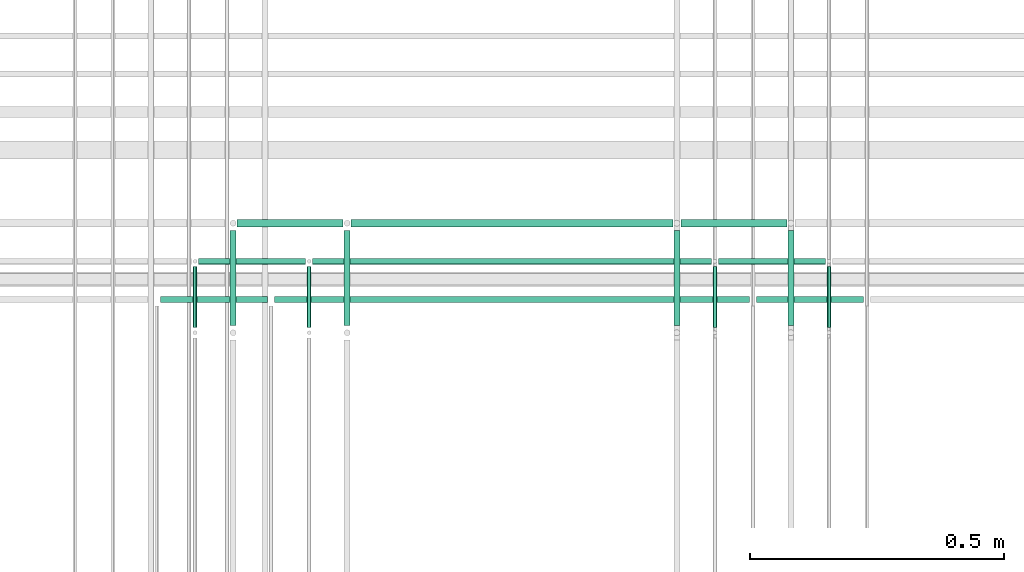
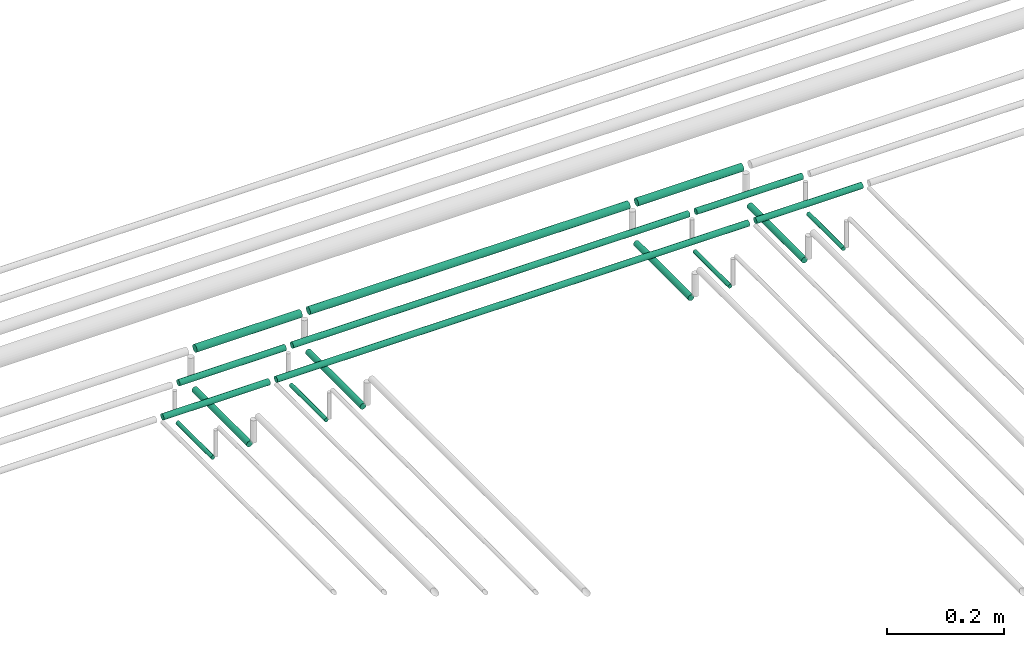
# One storey, part 141 of 331: 17 flow segments.
"""IFC2X3 building model written with IfcOpenShell, lengths in millimetres."""

import ifcopenshell
import ifcopenshell.guid

model = None  # the IFC model being written
_history = None  # IfcOwnerHistory: only IFC2X3 demands one
_inside = {}  # id of a spatial element -> (the spatial element, [elements in it])
_under = {}  # id of a project, library or spatial element -> (it, [spatial elements below it])
_declared = {}  # id of a project -> (the project, [libraries it declares])
_typed = {}  # id of a type object -> (the type object, [elements of that type])
_made_of = {}  # id of a material, layer set ... -> (it, [elements and type objects made of it])


def new_model(schema):
    """Start an empty IFC model of exactly this schema.

    Asked for "IFC4X3", IfcOpenShell would pick the latest addendum, in which some entities
    have other attributes; the version numbers below select the first issue.
    IFC2X3 requires an IfcOwnerHistory on every rooted entity: one is made here for all.
    """
    global model, _history
    if schema == "IFC4X3":
        model = ifcopenshell.file(schema_version=(4, 3, 0, 0))
    else:
        model = ifcopenshell.file(schema=schema)
    _inside.clear()
    _under.clear()
    _declared.clear()
    _typed.clear()
    _made_of.clear()
    _history = None
    if model.schema == "IFC2X3":
        org = make("IfcOrganization", Name="unknown")
        user = make(
            "IfcPersonAndOrganization",
            ThePerson=make("IfcPerson", FamilyName="unknown"),
            TheOrganization=org,
        )
        app = make(
            "IfcApplication",
            ApplicationDeveloper=org,
            Version="unknown",
            ApplicationFullName="unknown",
            ApplicationIdentifier="unknown",
        )
        _history = make(
            "IfcOwnerHistory",
            OwningUser=user,
            OwningApplication=app,
            ChangeAction="ADDED",
            CreationDate=0,
        )
    return model


def make(cls, **values):
    """One entity of the class cls with the attributes given. An attribute that is None is left unset."""
    return model.create_entity(
        cls, **{name: value for name, value in values.items() if value is not None}
    )


def entity(cls, *values):
    """Any entity or typed value of the class cls, its attributes in the order of the schema. None: left unset."""
    e = model.create_entity(cls)
    for i, value in enumerate(values):
        if value is not None:
            e[i] = value
    return e


def rooted(cls, **values):
    """An entity with a GlobalId (a new one), such as an element, a storey or a relation."""
    return make(cls, GlobalId=ifcopenshell.guid.new(), OwnerHistory=_history, **values)


def si_unit(unit_type, name, prefix=None):
    """IfcSIUnit, for example si_unit("LENGTHUNIT", "METRE", prefix="MILLI")."""
    return make("IfcSIUnit", UnitType=unit_type, Prefix=prefix, Name=name)


def converted_unit(unit_type, name, factor, base, dimensions=None, offset=None):
    """IfcConversionBasedUnit, such as the inch: factor (a typed value) times the base unit."""
    return make(
        "IfcConversionBasedUnit"
        if offset is None
        else "IfcConversionBasedUnitWithOffset",
        ConversionOffset=offset,
        Dimensions=None
        if dimensions is None
        else entity("IfcDimensionalExponents", *dimensions),
        UnitType=unit_type,
        Name=name,
        ConversionFactor=make(
            "IfcMeasureWithUnit", ValueComponent=factor, UnitComponent=base
        ),
    )


def derived_unit(unit_type, elements):
    """IfcDerivedUnit: a product of units, each with its exponent."""
    return make(
        "IfcDerivedUnit",
        Elements=[
            make("IfcDerivedUnitElement", Unit=unit, Exponent=power)
            for unit, power in elements
        ],
        UnitType=unit_type,
    )


def assignment(units):
    """IfcUnitAssignment: the units of a project."""
    return None if units is None else make("IfcUnitAssignment", Units=units)


def point(xyz):
    """IfcCartesianPoint."""
    return None if xyz is None else make("IfcCartesianPoint", Coordinates=xyz)


def direction(xyz):
    """IfcDirection."""
    return None if xyz is None else make("IfcDirection", DirectionRatios=xyz)


def frame(location, z_axis=None, x_axis=None):
    """IfcAxis2Placement3D, a coordinate frame: its origin and axes. An axis left out is left unset."""
    return make(
        "IfcAxis2Placement3D",
        Location=point(location),
        Axis=direction(z_axis),
        RefDirection=direction(x_axis),
    )


def frame_2d(location, x_axis=None):
    """IfcAxis2Placement2D, a coordinate frame in the plane: its origin and x axis."""
    return make(
        "IfcAxis2Placement2D", Location=point(location), RefDirection=direction(x_axis)
    )


def origin():
    """The frame at (0, 0, 0) with its axes left unset."""
    return frame((0.0, 0.0, 0.0))


def origin_2d_with_axis():
    """The frame at (0, 0) in the plane with the x axis (1, 0) written out."""
    return frame_2d((0.0, 0.0), x_axis=(1.0, 0.0))


def place(relative_to, where):
    """IfcLocalPlacement: puts the frame where relative to a parent placement (None: the world)."""
    return make(
        "IfcLocalPlacement", PlacementRelTo=relative_to, RelativePlacement=where
    )


def context(
    kind, dimensions, precision=None, world=None, true_north=None, identifier=None
):
    """IfcGeometricRepresentationContext, for example the 3D "Model" context."""
    return make(
        "IfcGeometricRepresentationContext",
        ContextIdentifier=identifier,
        ContextType=kind,
        CoordinateSpaceDimension=dimensions,
        Precision=precision,
        WorldCoordinateSystem=world,
        TrueNorth=true_north,
    )


def subcontext(parent, identifier, kind, view, scale=None):
    """IfcGeometricRepresentationSubContext, for example "Body" below "Model"."""
    return make(
        "IfcGeometricRepresentationSubContext",
        ContextIdentifier=identifier,
        ContextType=kind,
        ParentContext=parent,
        TargetScale=scale,
        TargetView=view,
    )


def project(units=None, contexts=None):
    """IfcProject with its units and contexts."""
    return rooted(
        "IfcProject",
        Name="project",
        RepresentationContexts=contexts,
        UnitsInContext=assignment(units),
    )


def spatial(cls, under=None, at=None, **own):
    """A site, building, storey or space (cls), placed at a placement, below another one or the project."""
    s = rooted(cls, ObjectPlacement=at, **own)
    if under is not None:
        _under.setdefault(under.id(), (under, []))[1].append(s)
    return s


def profile(cls, at=None, kind="AREA", **sizes):
    """A parametric profile (cls). Its sizes go by their IFC names, for example OverallWidth=200.0."""
    return make(cls, ProfileType=kind, Position=at, **sizes)


def circle(**sizes):
    """IfcCircleProfileDef."""
    return profile("IfcCircleProfileDef", **sizes)


def extrude(swept, where, along, depth):
    """IfcExtrudedAreaSolid: the profile swept, set in the frame where, extruded along a direction by depth."""
    return make(
        "IfcExtrudedAreaSolid",
        SweptArea=swept,
        Position=where,
        ExtrudedDirection=direction(along),
        Depth=depth,
    )


def shape(context_of_items, identifier, shape_type, items):
    """IfcShapeRepresentation: the items that make up one representation, for example the "Body"."""
    return make(
        "IfcShapeRepresentation",
        ContextOfItems=context_of_items,
        RepresentationIdentifier=identifier,
        RepresentationType=shape_type,
        Items=items,
    )


def made_of(thing, what):
    """Note that an element or type object is made of a material, layer set ...; save() writes the relation."""
    if what is not None:
        _made_of.setdefault(what.id(), (what, []))[1].append(thing)
    return thing


def type_object(cls, material=None, **own):
    """A type object (cls), such as IfcWallType, which elements share."""
    return made_of(rooted(cls, **own), material)


def element(
    cls,
    number,
    at=None,
    inside=None,
    cuts=None,
    type_object=None,
    material=None,
    context=None,
    identifier="Body",
    shape_type=None,
    held_by="IfcProductDefinitionShape",
    body=None,
    shapes=None,
    **own,
):
    """One element of the class cls, such as IfcWall. Its Tag is "e" and its number.

    at: its placement. inside: the storey or other place that contains it. cuts: it is an
    opening in that element (IfcRelVoidsElement). A single representation is given by context,
    identifier, shape_type and body (its items); several are given by shapes. held_by: the class
    of the entity that holds the representations. save() writes the other relations.
    """
    e = rooted(cls, Tag="e%d" % number, ObjectPlacement=at, **own)
    if body is not None:
        shapes = [shape(context, identifier, shape_type, body)]
    if shapes is not None:
        e.Representation = make(held_by, Representations=shapes)
    if inside is not None:
        _inside.setdefault(inside.id(), (inside, []))[1].append(e)
    if cuts is not None:
        rooted(
            "IfcRelVoidsElement", RelatingBuildingElement=cuts, RelatedOpeningElement=e
        )
    if type_object is not None:
        _typed.setdefault(type_object.id(), (type_object, []))[1].append(e)
    return made_of(e, material)


def aggregate(whole, parts):
    """IfcRelAggregates: a whole, such as a stair, and the parts it consists of."""
    return rooted("IfcRelAggregates", RelatingObject=whole, RelatedObjects=parts)


def save(model, path):
    """Write the relations noted so far, then the file.

    IfcRelAggregates (storeys below a building ...), IfcRelContainedInSpatialStructure (elements
    in a storey), IfcRelDefinesByType, IfcRelAssociatesMaterial and IfcRelDeclares: one each for
    every whole, place, type object, material and project.
    """
    for whole, parts in _under.values():
        aggregate(whole, parts)
    for where, things in _inside.values():
        rooted(
            "IfcRelContainedInSpatialStructure",
            RelatedElements=things,
            RelatingStructure=where,
        )
    for kind, things in _typed.values():
        rooted("IfcRelDefinesByType", RelatedObjects=things, RelatingType=kind)
    for what, things in _made_of.values():
        rooted("IfcRelAssociatesMaterial", RelatedObjects=things, RelatingMaterial=what)
    for by, libraries in _declared.values():
        rooted("IfcRelDeclares", RelatingContext=by, RelatedDefinitions=libraries)
    model.write(path)


model = new_model("IFC2X3")

# Units and contexts
model_context = context("Model", 3, precision=0.01, world=origin(), true_north=direction((6.12303176911189e-17, 1.0)))
body_context = subcontext(model_context, "Body", "Model", "MODEL_VIEW")
ifc_project = project(units=[si_unit("LENGTHUNIT", "METRE", prefix="MILLI"), si_unit("AREAUNIT", "SQUARE_METRE"), si_unit("VOLUMEUNIT", "CUBIC_METRE"), converted_unit("PLANEANGLEUNIT", "DEGREE", entity("IfcRatioMeasure", 0.0174532925199433), si_unit("PLANEANGLEUNIT", "RADIAN"), dimensions=[0, 0, 0, 0, 0, 0, 0]), si_unit("MASSUNIT", "GRAM", prefix="KILO"), derived_unit("MASSDENSITYUNIT", [(si_unit("MASSUNIT", "GRAM", prefix="KILO"), 1), (si_unit("LENGTHUNIT", "METRE"), -3)]), derived_unit("MOMENTOFINERTIAUNIT", [(si_unit("LENGTHUNIT", "METRE"), 4)]), si_unit("TIMEUNIT", "SECOND"), si_unit("FREQUENCYUNIT", "HERTZ"), si_unit("THERMODYNAMICTEMPERATUREUNIT", "DEGREE_CELSIUS"), derived_unit("THERMALTRANSMITTANCEUNIT", [(si_unit("MASSUNIT", "GRAM", prefix="KILO"), 1), (si_unit("THERMODYNAMICTEMPERATUREUNIT", "KELVIN"), -1), (si_unit("TIMEUNIT", "SECOND"), -3)]), derived_unit("VOLUMETRICFLOWRATEUNIT", [(si_unit("LENGTHUNIT", "METRE"), 3), (si_unit("TIMEUNIT", "SECOND"), -1)]), derived_unit("MASSFLOWRATEUNIT", [(si_unit("MASSUNIT", "GRAM", prefix="KILO"), 1), (si_unit("TIMEUNIT", "SECOND"), -1)]), derived_unit("ROTATIONALFREQUENCYUNIT", [(si_unit("TIMEUNIT", "SECOND"), -1)]), si_unit("ELECTRICCURRENTUNIT", "AMPERE"), si_unit("ELECTRICVOLTAGEUNIT", "VOLT"), si_unit("POWERUNIT", "WATT"), si_unit("FORCEUNIT", "NEWTON", prefix="KILO"), si_unit("ILLUMINANCEUNIT", "LUX"), si_unit("LUMINOUSFLUXUNIT", "LUMEN"), si_unit("LUMINOUSINTENSITYUNIT", "CANDELA"), derived_unit("USERDEFINED", [(si_unit("MASSUNIT", "GRAM", prefix="KILO"), -1), (si_unit("LENGTHUNIT", "METRE"), -2), (si_unit("TIMEUNIT", "SECOND"), 3), (si_unit("LUMINOUSFLUXUNIT", "LUMEN"), 1)]), derived_unit("LINEARVELOCITYUNIT", [(si_unit("LENGTHUNIT", "METRE"), 1), (si_unit("TIMEUNIT", "SECOND"), -1)]), si_unit("PRESSUREUNIT", "PASCAL"), derived_unit("USERDEFINED", [(si_unit("LENGTHUNIT", "METRE"), -2), (si_unit("MASSUNIT", "GRAM", prefix="KILO"), 1), (si_unit("TIMEUNIT", "SECOND"), -2)]), derived_unit("LINEARFORCEUNIT", [(si_unit("MASSUNIT", "GRAM", prefix="KILO"), 1), (si_unit("LENGTHUNIT", "METRE"), 1), (si_unit("TIMEUNIT", "SECOND"), -2), (si_unit("LENGTHUNIT", "METRE"), -1)]), derived_unit("PLANARFORCEUNIT", [(si_unit("MASSUNIT", "GRAM", prefix="KILO"), 1), (si_unit("LENGTHUNIT", "METRE"), 1), (si_unit("TIMEUNIT", "SECOND"), -2), (si_unit("LENGTHUNIT", "METRE"), -2)])], contexts=[model_context])

# Site, building, storey
site_placement = place(None, frame((0.0, -0.00077364408347762, 0.0)))
site = spatial("IfcSite", under=ifc_project, at=site_placement, CompositionType="ELEMENT")
building_placement = place(site_placement, origin())
building = spatial("IfcBuilding", under=site, at=building_placement, CompositionType="ELEMENT")
storey_placement = place(building_placement, origin())
storey = spatial("IfcBuildingStorey", under=building, at=storey_placement, CompositionType="ELEMENT", Elevation=0.0)

# Flow segments
pipe_segment_type = type_object("IfcPipeSegmentType", PredefinedType="NOTDEFINED")
flow_segment_1_placement = place(storey_placement, frame((26165.5132663482, 8100.14924977616, 14469.404727873)))
element("IfcFlowSegment", 1, at=flow_segment_1_placement, inside=storey, type_object=pipe_segment_type, context=body_context, shape_type="SweptSolid", body=[
    extrude(circle(Radius=4.0, at=origin_2d_with_axis()), frame((5.59527223591499, 0.0, 5.59527223591499), z_axis=(0.0, 1.0, 0.0), x_axis=(1.0, 0.0, 0.0)), (0.0, 0.0, 1.0), 120.860694073175),
])
flow_segment_2_placement = place(storey_placement, frame((26390.5132663482, 8100.14924977616, 14469.404727873)))
element("IfcFlowSegment", 2, at=flow_segment_2_placement, inside=storey, type_object=pipe_segment_type, context=body_context, shape_type="SweptSolid", body=[
    extrude(circle(Radius=4.0, at=origin_2d_with_axis()), frame((5.59527223591499, 0.0, 5.59527223591499), z_axis=(0.0, 1.0, 0.0), x_axis=(1.0, 0.0, 0.0)), (0.0, 0.0, 1.0), 120.860694073173),
])
flow_segment_3_placement = place(storey_placement, frame((26088.5132663482, 8104.14924977617, 14467.404727873)))
element("IfcFlowSegment", 3, at=flow_segment_3_placement, inside=storey, type_object=pipe_segment_type, context=body_context, shape_type="SweptSolid", body=[
    extrude(circle(Radius=6.0, at=origin_2d_with_axis()), frame((7.59527223591454, 0.0, 7.5952722359167), z_axis=(0.0, 1.0, 0.0), x_axis=(1.0, 0.0, 0.0)), (0.0, 0.0, 1.0), 187.860694073163),
])
flow_segment_4_placement = place(storey_placement, frame((26313.5132663482, 8104.14924977616, 14467.404727873)))
element("IfcFlowSegment", 4, at=flow_segment_4_placement, inside=storey, type_object=pipe_segment_type, context=body_context, shape_type="SweptSolid", body=[
    extrude(circle(Radius=6.0, at=origin_2d_with_axis()), frame((7.59527223591454, 0.0, 7.5952722359167), z_axis=(0.0, 1.0, 0.0), x_axis=(1.0, 0.0, 0.0)), (0.0, 0.0, 1.0), 187.860694073173),
])
flow_segment_5_placement = place(storey_placement, frame((25365.5132663482, 8100.14924977616, 14469.404727873)))
element("IfcFlowSegment", 5, at=flow_segment_5_placement, inside=storey, type_object=pipe_segment_type, context=body_context, shape_type="SweptSolid", body=[
    extrude(circle(Radius=4.0, at=origin_2d_with_axis()), frame((5.59527223591499, 0.0, 5.59527223591499), z_axis=(0.0, 1.0, 0.0), x_axis=(1.0, 0.0, 0.0)), (0.0, 0.0, 1.0), 120.860694073177),
])
flow_segment_6_placement = place(storey_placement, frame((25140.5132663482, 8100.14924977616, 14469.404727873)))
element("IfcFlowSegment", 6, at=flow_segment_6_placement, inside=storey, type_object=pipe_segment_type, context=body_context, shape_type="SweptSolid", body=[
    extrude(circle(Radius=4.0, at=origin_2d_with_axis()), frame((5.59527223591499, 0.0, 5.59527223591499), z_axis=(0.0, 1.0, 0.0), x_axis=(1.0, 0.0, 0.0)), (0.0, 0.0, 1.0), 120.860694073179),
])
flow_segment_7_placement = place(storey_placement, frame((25438.5132663482, 8104.14924977618, 14467.404727873)))
element("IfcFlowSegment", 7, at=flow_segment_7_placement, inside=storey, type_object=pipe_segment_type, context=body_context, shape_type="SweptSolid", body=[
    extrude(circle(Radius=6.0, at=origin_2d_with_axis()), frame((7.59527223591454, 0.0, 7.5952722359167), z_axis=(0.0, 1.0, 0.0), x_axis=(1.0, 0.0, 0.0)), (0.0, 0.0, 1.0), 187.860694073163),
])
flow_segment_8_placement = place(storey_placement, frame((25213.5132663482, 8104.14924977616, 14467.404727873)))
element("IfcFlowSegment", 8, at=flow_segment_8_placement, inside=storey, type_object=pipe_segment_type, context=body_context, shape_type="SweptSolid", body=[
    extrude(circle(Radius=6.0, at=origin_2d_with_axis()), frame((7.59527223591454, 0.0, 7.5952722359167), z_axis=(0.0, 1.0, 0.0), x_axis=(1.0, 0.0, 0.0)), (0.0, 0.0, 1.0), 187.860694073177),
])
flow_segment_9_placement = place(storey_placement, frame((26253.1085385841, 8148.41467161334, 14542.4047277641)))
element("IfcFlowSegment", 9, at=flow_segment_9_placement, inside=storey, type_object=pipe_segment_type, context=body_context, shape_type="SweptSolid", body=[
    extrude(circle(Radius=6.0, at=frame_2d((4.33146851719357e-12, 0.0), x_axis=(1.0, 0.0))), frame((0.0, 7.59527223591995, 7.5952722359167), z_axis=(1.0, 0.0, 0.0), x_axis=(0.0, 1.0, 0.0)), (0.0, 0.0, 1.0), 211.0),
])
flow_segment_10_placement = place(storey_placement, frame((25303.1085385841, 8148.41467161333, 14542.4047277641)))
element("IfcFlowSegment", 10, at=flow_segment_10_placement, inside=storey, type_object=pipe_segment_type, context=body_context, shape_type="SweptSolid", body=[
    extrude(circle(Radius=6.0, at=frame_2d((4.33146851719357e-12, 0.0), x_axis=(1.0, 0.0))), frame((0.0, 7.59527223591995, 7.5952722359167), z_axis=(1.0, 0.0, 0.0), x_axis=(0.0, 1.0, 0.0)), (0.0, 0.0, 1.0), 935.999999999974),
])
flow_segment_11_placement = place(storey_placement, frame((25078.1085385841, 8148.41467161332, 14542.4047277641)))
element("IfcFlowSegment", 11, at=flow_segment_11_placement, inside=storey, type_object=pipe_segment_type, context=body_context, shape_type="SweptSolid", body=[
    extrude(circle(Radius=6.0, at=frame_2d((4.33146851719357e-12, 0.0), x_axis=(1.0, 0.0))), frame((0.0, 7.59527223591995, 7.5952722359167), z_axis=(1.0, 0.0, 0.0), x_axis=(0.0, 1.0, 0.0)), (0.0, 0.0, 1.0), 211.0),
])
flow_segment_12_placement = place(storey_placement, frame((26178.1085425053, 8223.41467161342, 14542.4043991215)))
element("IfcFlowSegment", 12, at=flow_segment_12_placement, inside=storey, type_object=pipe_segment_type, context=body_context, shape_type="SweptSolid", body=[
    extrude(circle(Radius=6.0, at=frame_2d((-2.16573425859679e-12, -2.16573425859679e-12), x_axis=(1.0, 0.0))), frame((0.0, 7.59527223591778, 7.59527223591887), z_axis=(1.0, 0.0, 0.0), x_axis=(0.0, 1.0, 0.0)), (0.0, 0.0, 1.0), 210.999999999995),
])
flow_segment_13_placement = place(storey_placement, frame((25378.1085425053, 8223.41467161342, 14542.4044089245)))
element("IfcFlowSegment", 13, at=flow_segment_13_placement, inside=storey, type_object=pipe_segment_type, context=body_context, shape_type="SweptSolid", body=[
    extrude(circle(Radius=6.0, at=frame_2d((-1.08286712929839e-12, 0.0), x_axis=(1.0, 0.0))), frame((0.0, 7.5952722359167, 7.5952722359167), z_axis=(1.0, 0.0, 0.0), x_axis=(0.0, 1.0, 0.0)), (0.0, 0.0, 1.0), 785.999999999986),
])
flow_segment_14_placement = place(storey_placement, frame((25153.1085425053, 8223.41467161342, 14542.4044437796)))
element("IfcFlowSegment", 14, at=flow_segment_14_placement, inside=storey, type_object=pipe_segment_type, context=body_context, shape_type="SweptSolid", body=[
    extrude(circle(Radius=6.0, at=frame_2d((-2.16573425859679e-12, 0.0), x_axis=(1.0, 0.0))), frame((0.0, 7.59527223591778, 7.5952722359167), z_axis=(1.0, 0.0, 0.0), x_axis=(0.0, 1.0, 0.0)), (0.0, 0.0, 1.0), 211.0),
])
flow_segment_15_placement = place(storey_placement, frame((26104.1085341706, 8296.91467161342, 14540.9033902414)))
element("IfcFlowSegment", 15, at=flow_segment_15_placement, inside=storey, type_object=pipe_segment_type, context=body_context, shape_type="SweptSolid", body=[
    extrude(circle(Radius=7.5, at=frame_2d((-1.08286712929839e-12, 7.78132442118943e-31), x_axis=(1.0, 0.0))), frame((0.0, 9.09527223591744, 9.09527223591636), z_axis=(1.0, 0.0, 0.0), x_axis=(0.0, 1.0, 0.0)), (0.0, 0.0, 1.0), 209.000000000004),
])
flow_segment_16_placement = place(storey_placement, frame((25454.1085341706, 8296.91467161342, 14540.9033786943)))
element("IfcFlowSegment", 16, at=flow_segment_16_placement, inside=storey, type_object=pipe_segment_type, context=body_context, shape_type="SweptSolid", body=[
    extrude(circle(Radius=7.5, at=frame_2d((-1.08286712929839e-12, 7.78132442118943e-31), x_axis=(1.0, 0.0))), frame((0.0, 9.09527223591744, 9.09527223591636), z_axis=(1.0, 0.0, 0.0), x_axis=(0.0, 1.0, 0.0)), (0.0, 0.0, 1.0), 633.999999999977),
])
flow_segment_17_placement = place(storey_placement, frame((25229.1085341706, 8296.91467161342, 14540.9033453358)))
element("IfcFlowSegment", 17, at=flow_segment_17_placement, inside=storey, type_object=pipe_segment_type, context=body_context, shape_type="SweptSolid", body=[
    extrude(circle(Radius=7.5, at=frame_2d((-1.08286712929839e-12, 7.78132442118943e-31), x_axis=(1.0, 0.0))), frame((0.0, 9.09527223591744, 9.09527223591636), z_axis=(1.0, 0.0, 0.0), x_axis=(0.0, 1.0, 0.0)), (0.0, 0.0, 1.0), 209.000000000004),
])

save(model, "model.ifc")
